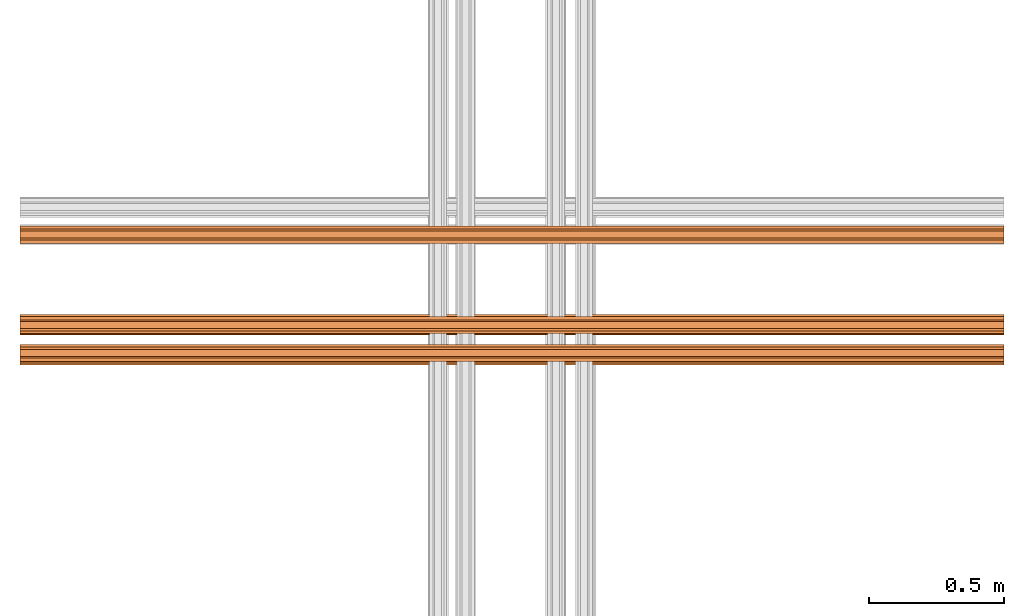
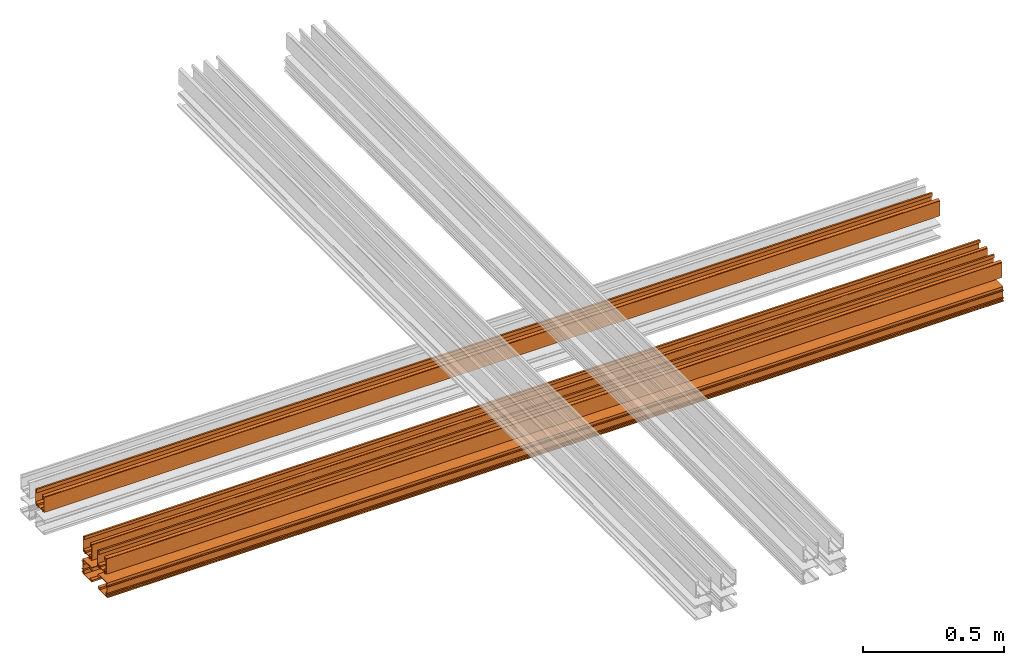
# One storey, part 1 of 4: 5 proxies.
"""IFC2X3 building model written with IfcOpenShell, lengths in feet."""

from ifc_helpers import new_model, entity, si_unit, converted_unit, derived_unit, direction, frame, origin, place, context, subcontext, project, spatial, polyline, outline, extrude, source, transform, mapped, material, type_object, type_shapes, element, save


model = new_model("IFC2X3")

# Units and contexts
model_context = context("Model", 3, precision=0.0001, world=origin(), true_north=direction((6.12303176911189e-17, 1.0)))
body_context = subcontext(model_context, "Body", "Model", "MODEL_VIEW")
ifc_project = project(units=[converted_unit("LENGTHUNIT", "FOOT", entity("IfcRatioMeasure", 0.3048), si_unit("LENGTHUNIT", "METRE"), dimensions=[1, 0, 0, 0, 0, 0, 0]), converted_unit("AREAUNIT", "SQUARE FOOT", entity("IfcRatioMeasure", 0.09290304), si_unit("AREAUNIT", "SQUARE_METRE"), dimensions=[2, 0, 0, 0, 0, 0, 0]), converted_unit("VOLUMEUNIT", "CUBIC FOOT", entity("IfcRatioMeasure", 0.028316846592), si_unit("VOLUMEUNIT", "CUBIC_METRE"), dimensions=[3, 0, 0, 0, 0, 0, 0]), converted_unit("PLANEANGLEUNIT", "DEGREE", entity("IfcRatioMeasure", 0.0174532925199433), si_unit("PLANEANGLEUNIT", "RADIAN"), dimensions=[0, 0, 0, 0, 0, 0, 0]), si_unit("MASSUNIT", "GRAM", prefix="KILO"), derived_unit("MASSDENSITYUNIT", [(si_unit("MASSUNIT", "GRAM", prefix="KILO"), 1), (si_unit("LENGTHUNIT", "METRE"), -3)]), si_unit("TIMEUNIT", "SECOND"), si_unit("FREQUENCYUNIT", "HERTZ"), si_unit("THERMODYNAMICTEMPERATUREUNIT", "DEGREE_CELSIUS"), derived_unit("THERMALTRANSMITTANCEUNIT", [(si_unit("MASSUNIT", "GRAM", prefix="KILO"), 1), (si_unit("THERMODYNAMICTEMPERATUREUNIT", "KELVIN"), -1), (si_unit("TIMEUNIT", "SECOND"), -3)]), derived_unit("VOLUMETRICFLOWRATEUNIT", [(si_unit("LENGTHUNIT", "METRE"), 3), (si_unit("TIMEUNIT", "SECOND"), -1)]), si_unit("ELECTRICCURRENTUNIT", "AMPERE"), si_unit("ELECTRICVOLTAGEUNIT", "VOLT"), si_unit("POWERUNIT", "WATT"), si_unit("FORCEUNIT", "NEWTON"), si_unit("ILLUMINANCEUNIT", "LUX"), si_unit("LUMINOUSFLUXUNIT", "LUMEN"), si_unit("LUMINOUSINTENSITYUNIT", "CANDELA"), derived_unit("USERDEFINED", [(si_unit("MASSUNIT", "GRAM", prefix="KILO"), -1), (si_unit("LENGTHUNIT", "METRE"), -2), (si_unit("TIMEUNIT", "SECOND"), 3), (si_unit("LUMINOUSFLUXUNIT", "LUMEN"), 1)]), derived_unit("LINEARVELOCITYUNIT", [(si_unit("LENGTHUNIT", "METRE"), 1), (si_unit("TIMEUNIT", "SECOND"), -1)]), si_unit("PRESSUREUNIT", "PASCAL"), derived_unit("USERDEFINED", [(si_unit("LENGTHUNIT", "METRE"), -2), (si_unit("MASSUNIT", "GRAM", prefix="KILO"), 1), (si_unit("TIMEUNIT", "SECOND"), -2)])], contexts=[model_context])

# Site, building, storey
site_placement = place(None, origin())
site = spatial("IfcSite", under=ifc_project, at=site_placement, CompositionType="ELEMENT")
building_placement = place(site_placement, origin())
building = spatial("IfcBuilding", under=site, at=building_placement, CompositionType="ELEMENT")
storey_placement = place(building_placement, origin())
storey = spatial("IfcBuildingStorey", under=building, at=storey_placement, Name="Level 1", CompositionType="ELEMENT", Elevation=0.0)

# Proxies
ifc_material = material(Name="THERMAL BROKEN ALUMINUM STOREFRONT FOR POLYCARBONATE")
building_element_proxy_type_1 = type_object("IfcBuildingElementProxyType", Name="Generic Models 2", PredefinedType="NOTDEFINED", material=ifc_material)
shared_shape_1 = source(origin(), body_context, "Body", "SweptSolid", [
    extrude(outline(polyline([(-0.0354587820648085, -0.057987428976448), (-0.0371114306935168, -0.0606344277326356), (-0.0357721806658748, -0.0632292686235394), (-0.0318167433379175, -0.0629517678914727), (-0.0277772795930213, -0.0651918706200439), (-0.0314564692543419, -0.0718263669125334), (-0.0224403589082045, -0.0768262913240349), (0.080199598822188, 0.108259143706009), (0.064548992183561, 0.116938257778831), (0.0595490677720596, 0.107922147432694), (0.0641808354764016, 0.104241425091678), (0.0513416446814541, 0.093122117241815), (0.0445492945375549, 0.0808738163942816), (0.0511837908300444, 0.0771946267329609), (-0.0196641946988638, -0.0505619557187231), (-0.0545378290564901, -0.0312226254478626), (-0.0567210844599416, -0.0351595792918124), (-0.0305624709345729, -0.0549725228627147), (-0.0322344006357104, -0.057987428976448), (-0.0354587820648085, -0.057987428976448)])), frame((0.0, -0.190699332335291, 0.0977165289076384), z_axis=(-1.0, 0.0, 0.0), x_axis=(0.0, -0.874528680516531, 0.484973800275866)), (0.0, 0.0, -1.0), 12.0),
    extrude(outline(polyline([(-0.0178285177675853, -0.0155260272187074), (-0.0144209943882479, -0.0155260272187074), (-0.0144209943882479, -0.00196676824874472), (-0.00206457119881483, -0.00196676824874479), (-0.00122137518562371, -0.00702594432743677), (0.0126070394294665, -0.00196676824874489), (0.027466410094602, -0.00196676824874498), (0.027466410094602, 0.00198764102988935), (0.0102463757664149, 0.0219787153649708), (-0.027829782456566, 0.021978715364971), (-0.0178285177675853, -0.0155260272187074)])), frame((0.0, -0.187517152962419, 0.217514651613355), z_axis=(1.0, 0.0, 0.0), x_axis=(0.0, 0.0, -1.0)), (0.0, 0.0, 1.0), 12.0),
    extrude(outline(polyline([(-0.10703462932325, -0.0730229494703186), (-0.10703462932325, -0.0580447359626438), (-0.113745897781071, -0.0580447359626438), (-0.118025006955696, -0.0623242255363626), (-0.112092207910207, -0.0623242255363626), (-0.112092207910207, -0.0671872818698963), (-0.11773967307098, -0.0704478474007052), (-0.125224643652343, -0.0704478474007052), (-0.131454279657517, -0.0675429204239743), (-0.131454279657517, -0.0623242255363626), (-0.124783598829804, -0.0623242255363626), (-0.125514243391176, -0.0580447359626438), (-0.142048634925557, -0.0580447359626438), (-0.140085232742292, -0.0813874063643331), (0.0647285203812249, -0.0813874063643331), (0.0647285203812249, -0.0697160711634884), (0.0853478792356714, -0.0697160711634884), (0.0853478792356714, -0.0631023145498281), (0.0647285203809975, -0.0631023145498281), (0.0647285203809975, -0.0273102199340561), (0.0853478792356715, -0.0273102199340561), (0.0853478792356715, -0.0206964633203958), (0.0647285203809975, -0.0206964633203958), (0.0647285203809975, 0.0812331974328894), (0.0853478792356714, 0.0812331974328894), (0.0853478792356714, 0.0878469540465497), (0.0647285203812249, 0.0878469540465497), (0.0647285203812249, 0.116052680781773), (0.0602545085540829, 0.116052680781773), (0.0585038082739668, 0.113329369234955), (0.0606435530609293, 0.110217013181205), (0.0606435530609293, 0.0878469540467771), (0.0563640634872104, 0.0835674644730583), (0.0563640634872105, 0.0713125625121714), (0.0388570606861708, 0.0713125625121714), (0.0388570606861709, 0.11546911402173), (0.033799482099214, 0.11546911402173), (0.033799482099214, 0.0646988058985111), (0.0563640634872104, 0.0646988058985111), (0.0563640634872105, -0.0203074188135494), (0.033799482099214, -0.0203074188135494), (0.033799482099214, -0.0730229494703186), (-0.10703462932325, -0.0730229494703186)]), holes=[polyline([(0.0577257192607181, -0.0710777269369961), (0.0388570606861709, -0.0710777269369961), (0.0388570606861709, -0.0273102199340561), (0.0577257192607181, -0.0273102199340561), (0.0577257192607181, -0.0710777269369961)])]), frame((0.0, -0.0813874063643477, 0.0853478792356716), z_axis=(-1.0, 0.0, 0.0), x_axis=(0.0, 0.0, -1.0)), (0.0, 0.0, -1.0), 12.0),
    extrude(outline(polyline([(-0.0292228042856085, -0.0158518272304065), (0.0188500922736237, -0.0158518272304065), (0.0188500922736237, -0.00589636662728312), (0.0115395937546053, -0.00589636662728311), (0.00550806035789697, 0.000135166769425167), (0.0129043470694795, 0.000135166769425165), (0.0129043470694795, 0.00370861456478618), (0.00801477925506001, 0.00653160785866192), (0.00118965299247954, 0.00653160785866192), (-0.00472072620232233, 0.00377555277752608), (-0.00472072620232233, 0.000414827901224136), (0.00196648946985067, 0.000414827901224136), (0.00088896845272922, -0.00589636662728308), (-0.0169597840697408, -0.00589636662728307), (-0.0150489881052633, 0.0168208742845053), (-0.0219433941035701, 0.0168208742845053), (-0.0292228042856085, -0.0158518272304065)])), frame((0.0, -0.0184530145665469, 0.211232600832546), z_axis=(1.0, 0.0, 0.0), x_axis=(0.0, 0.0, -1.0)), (0.0, 0.0, 1.0), 12.0),
])
type_shapes(building_element_proxy_type_1, [shared_shape_1])
proxy_1_placement = place(storey_placement, frame((0.0, 0.0, 0.30116151530084)))
element("IfcBuildingElementProxy", 1, at=proxy_1_placement, inside=storey, type_object=building_element_proxy_type_1, material=ifc_material, Name="Generic Models 2:Generic Models 2", ObjectType="Generic Models 2:Generic Models 2", context=body_context, shape_type="MappedRepresentation", body=[
    mapped(shared_shape_1, transform((0.0, 0.0, 0.0), scale=1.0)),
])
building_element_proxy_type_2 = type_object("IfcBuildingElementProxyType", Name="Generic Models 2", PredefinedType="NOTDEFINED", material=ifc_material)
shared_shape_2 = source(origin(), body_context, "Body", "SweptSolid", [
    extrude(outline(polyline([(0.0679666623619384, 0.000632417738882162), (0.0710872151823903, 0.000632417738882162), (0.0725790120391962, 0.00314266314992655), (0.0702488184526767, 0.00635088523716425), (0.0700096732994308, 0.0109637083615168), (0.0775858665392128, 0.0113564851588286), (0.07705209294287, 0.0216523375102515), (-0.134304272308872, 0.0106948719853338), (-0.133377721915217, -0.00717717360587128), (-0.123081869563794, -0.00664340000952848), (-0.122412698736183, -0.000765203056200318), (-0.106181130798194, -0.00576720561552888), (-0.0921943125095252, -0.00504207922050014), (-0.0925870893068369, 0.00253411401928196), (0.0533031958989614, 0.0100975851674487), (0.0553677918848112, -0.0297259946823093), (0.0598635549062831, -0.0294929183410441), (0.0628161856570255, 0.00318899968962131), (0.0662590259738257, 0.00336748877384745), (0.0679666623619384, 0.000632417738882162)])), frame((0.0, 0.320001633810788, 0.0977165289076384), z_axis=(1.0, 0.0, 0.0), x_axis=(0.0, -0.0517740246052127, -0.998658825813991)), (0.0, 0.0, 1.0), 12.0),
    extrude(outline(polyline([(-0.0104080468283571, -0.0212270141141865), (0.0284072982254618, -0.0212270141141865), (0.0185964943745739, 0.0155635003266429), (-0.00515653981588804, 0.0270511459549446), (-0.00897742822638789, 0.0260322423788113), (-0.00514872339515063, 0.0116745992616715), (-0.0064740101252062, -0.00299045881680825), (-0.00136839731267844, -0.0025016235475988), (0.00181539143775603, -0.0144408313617281), (-0.0112860383341235, -0.0179345459675626), (-0.0104080468283571, -0.0212270141141865)])), frame((0.0, 0.316819454437916, 0.217514651613355), z_axis=(1.0, 0.0, 0.0), x_axis=(0.0, -0.966234939601246, 0.257662650560335)), (0.0, 0.0, 1.0), 12.0),
    extrude(outline(polyline([(-0.0730229494703184, 0.10703462932325), (-0.0580447359626436, 0.10703462932325), (-0.0580447359626435, 0.113745897781071), (-0.0623242255363624, 0.118025006955696), (-0.0623242255363624, 0.112092207910207), (-0.067187281869896, 0.112092207910207), (-0.0704478474007049, 0.11773967307098), (-0.0704478474007049, 0.125224643652343), (-0.067542920423974, 0.131454279657517), (-0.0623242255363623, 0.131454279657517), (-0.0623242255363623, 0.124783598829804), (-0.0580447359626436, 0.125514243391176), (-0.0580447359626435, 0.142048634925557), (-0.0813874063643328, 0.140085232742292), (-0.0813874063643332, -0.0647285203812247), (-0.0697160711634885, -0.0647285203812247), (-0.0697160711634886, -0.0853478792356713), (-0.0631023145498282, -0.0853478792356713), (-0.0631023145498282, -0.0647285203809974), (-0.0273102199340562, -0.0647285203809974), (-0.0273102199340562, -0.0853478792356714), (-0.0206964633203959, -0.0853478792356714), (-0.0206964633203959, -0.0647285203809975), (0.0812331974328893, -0.0647285203809976), (0.0812331974328893, -0.0853478792356716), (0.0878469540465496, -0.0853478792356716), (0.0878469540465496, -0.064728520381225), (0.116052680781773, -0.0647285203812251), (0.116052680781773, -0.060254508554083), (0.113329369234955, -0.058503808273967), (0.110217013181205, -0.0606435530609294), (0.0878469540467771, -0.0606435530609294), (0.0835674644730583, -0.0563640634872106), (0.0713125625121714, -0.0563640634872106), (0.0713125625121713, -0.038857060686171), (0.11546911402173, -0.0388570606861711), (0.11546911402173, -0.0337994820992142), (0.064698805898511, -0.0337994820992141), (0.064698805898511, -0.0563640634872105), (-0.0203074188135494, -0.0563640634872104), (-0.0203074188135494, -0.033799482099214), (-0.0730229494703186, -0.0337994820992139), (-0.0730229494703184, 0.10703462932325)]), holes=[polyline([(-0.0710777269369962, -0.057725719260718), (-0.0710777269369962, -0.0388570606861707), (-0.0273102199340562, -0.0388570606861708), (-0.0273102199340562, -0.0577257192607181), (-0.0710777269369962, -0.057725719260718)])]), frame((0.0, 0.210689707839845, 0.0853478792356716), z_axis=(1.0, 0.0, 0.0), x_axis=(0.0, 1.0, 0.0)), (0.0, 0.0, 1.0), 12.0),
    extrude(outline(polyline([(-0.0218274236802372, -0.0250762096884888), (0.0116463755794956, -0.0250762096884888), (0.0131456738465899, -0.0183468011873071), (-0.00944342914962784, -0.0152716423802919), (-0.00556193395869954, 0.00214995231397123), (0.000832544625431264, 0.00182921635388849), (-0.000621696809064671, -0.00469796031725742), (0.00265859892029523, -0.00542880340721438), (0.00663400184610042, -0.000259219921661488), (0.00811823413249319, 0.00640256685218492), (0.00642611525779217, 0.0117890219260675), (0.00293818751194471, 0.0125661249989722), (0.00132974729935321, 0.0053468468354401), (-0.00324578604653776, 0.01254568596629), (-0.00165600184121947, 0.0196812290274094), (-0.0113732075341089, 0.0218462023164868), (-0.0218274236802372, -0.0250762096884888)])), frame((0.0, 0.147755316042044, 0.211232600832546), z_axis=(1.0, 0.0, 0.0), x_axis=(0.0, -0.976067916921979, -0.217465908950321)), (0.0, 0.0, 1.0), 12.0),
])
type_shapes(building_element_proxy_type_2, [shared_shape_2])
proxy_2_placement = place(storey_placement, frame((0.0, 0.0, 0.30116151530084)))
element("IfcBuildingElementProxy", 2, at=proxy_2_placement, inside=storey, type_object=building_element_proxy_type_2, material=ifc_material, Name="Generic Models 1:Generic Models 2", ObjectType="Generic Models 1:Generic Models 2", context=body_context, shape_type="MappedRepresentation", body=[
    mapped(shared_shape_2, transform((0.0, 0.0, 0.0), scale=1.0)),
])
building_element_proxy_type_3 = type_object("IfcBuildingElementProxyType", Name="Generic Models 2", PredefinedType="NOTDEFINED", material=ifc_material)
shared_shape_3 = source(origin(), body_context, "Body", "SweptSolid", [
    extrude(outline(polyline([(-0.10703462932325, -0.0730229494703186), (-0.10703462932325, -0.0580447359626438), (-0.113745897781071, -0.0580447359626439), (-0.118025006955696, -0.0623242255363627), (-0.112092207910207, -0.0623242255363626), (-0.112092207910207, -0.0671872818698964), (-0.11773967307098, -0.0704478474007053), (-0.125224643652343, -0.0704478474007053), (-0.131454279657517, -0.0675429204239743), (-0.131454279657516, -0.0623242255363626), (-0.124783598829804, -0.0623242255363625), (-0.125514243391176, -0.0580447359626438), (-0.142048634925557, -0.0580447359626438), (-0.140085232742292, -0.0813874063643331), (0.0647285203812249, -0.0813874063643332), (0.0647285203812249, -0.0697160711634884), (0.0853478792356715, -0.0697160711634884), (0.0853478792356715, -0.0631023145498281), (0.0647285203809975, -0.0631023145498281), (0.0647285203809975, -0.0273102199340562), (0.0853478792356714, -0.0273102199340561), (0.0853478792356714, -0.0206964633203958), (0.0647285203809975, -0.0206964633203958), (0.0647285203809975, 0.0812331974328894), (0.0853478792356714, 0.0812331974328894), (0.0853478792356715, 0.0878469540465497), (0.0647285203812249, 0.0878469540465497), (0.0647285203812249, 0.116052680781773), (0.0602545085540829, 0.116052680781773), (0.0585038082739668, 0.113329369234955), (0.0606435530609293, 0.110217013181205), (0.0606435530609293, 0.0878469540467771), (0.0563640634872105, 0.0835674644730583), (0.0563640634872105, 0.0713125625121714), (0.0388570606861709, 0.0713125625121714), (0.0388570606861709, 0.11546911402173), (0.033799482099214, 0.11546911402173), (0.033799482099214, 0.0646988058985111), (0.0563640634872105, 0.0646988058985111), (0.0563640634872105, -0.0203074188135494), (0.033799482099214, -0.0203074188135494), (0.033799482099214, -0.0730229494703186), (-0.10703462932325, -0.0730229494703186)]), holes=[polyline([(0.0577257192607181, -0.0710777269369961), (0.0388570606861709, -0.0710777269369962), (0.0388570606861709, -0.0273102199340561), (0.0577257192607181, -0.0273102199340561), (0.0577257192607181, -0.0710777269369961)])]), frame((0.0, -0.117978010729643, -0.219774108936509), z_axis=(-1.0, 0.0, 0.0), x_axis=(0.0, -1.0, 0.0)), (0.0, 0.0, -1.0), 12.0),
    extrude(outline(polyline([(-0.035458782064809, -0.0579874289764477), (-0.0371114306935174, -0.0606344277326353), (-0.0357721806658754, -0.0632292686235391), (-0.031816743337918, -0.0629517678914724), (-0.0277772795930219, -0.0651918706200437), (-0.0314564692543425, -0.0718263669125332), (-0.0224403589082052, -0.0768262913240348), (0.0801995988221891, 0.108259143706008), (0.0645489921835621, 0.116938257778831), (0.0595490677720606, 0.107922147432693), (0.0641808354764026, 0.104241425091677), (0.0513416446814549, 0.0931221172418145), (0.0445492945375557, 0.0808738163942812), (0.0511837908300452, 0.0771946267329605), (-0.0196641946988643, -0.0505619557187229), (-0.0545378290564904, -0.0312226254478621), (-0.056721084459942, -0.0351595792918119), (-0.0305624709345734, -0.0549725228627144), (-0.0322344006357109, -0.0579874289764477), (-0.035458782064809, -0.0579874289764477)])), frame((0.0, -0.105609361057676, -0.110462182965566), z_axis=(-1.0, 0.0, 0.0), x_axis=(0.0, 0.484973800275872, 0.874528680516527)), (0.0, 0.0, -1.0), 12.0),
    extrude(outline(polyline([(-0.0178285177675856, -0.015526027218707), (-0.0144209943882483, -0.015526027218707), (-0.0144209943882479, -0.00196676824874445), (-0.00206457119881486, -0.00196676824874474), (-0.00122137518562389, -0.00702594432743677), (0.0126070394294665, -0.00196676824874522), (0.027466410094602, -0.00196676824874559), (0.0274664100946021, 0.00198764102988874), (0.0102463757664154, 0.0219787153649705), (-0.0278297824565654, 0.0219787153649716), (-0.0178285177675856, -0.015526027218707)])), frame((0.0, 0.0141887616480401, -0.113644362338437), z_axis=(1.0, 0.0, 0.0), x_axis=(0.0, -1.0, 0.0)), (0.0, 0.0, 1.0), 12.0),
    extrude(outline(polyline([(-0.0292228042856086, -0.0158518272304064), (0.0188500922736237, -0.0158518272304064), (0.0188500922736237, -0.00589636662728305), (0.0115395937546053, -0.00589636662728303), (0.00550806035789696, 0.000135166769425191), (0.0129043470694794, 0.000135166769425221), (0.0129043470694794, 0.00370861456478623), (0.00801477925505999, 0.00653160785866194), (0.00118965299247949, 0.00653160785866197), (-0.00472072620232236, 0.00377555277752608), (-0.00472072620232237, 0.000414827901224118), (0.00196648946985058, 0.000414827901224151), (0.000888968452729204, -0.00589636662728305), (-0.0169597840697408, -0.0058963666272831), (-0.0150489881052633, 0.0168208742845054), (-0.0219433941035702, 0.0168208742845054), (-0.0292228042856086, -0.0158518272304064)])), frame((0.0, 0.00790671086723129, -0.28270850073431), z_axis=(1.0, 0.0, 0.0), x_axis=(0.0, -1.0, 0.0)), (0.0, 0.0, 1.0), 12.0),
])
type_shapes(building_element_proxy_type_3, [shared_shape_3])
proxy_3_placement = place(storey_placement, frame((0.0, -0.0468749999999995, 0.30116151530084)))
element("IfcBuildingElementProxy", 3, at=proxy_3_placement, inside=storey, type_object=building_element_proxy_type_3, material=ifc_material, Name="Generic Models 5:Generic Models 2", ObjectType="Generic Models 5:Generic Models 2", context=body_context, shape_type="MappedRepresentation", body=[
    mapped(shared_shape_3, transform((0.0, 0.0, 0.0), scale=1.0)),
])
building_element_proxy_type_4 = type_object("IfcBuildingElementProxyType", Name="Generic Models 2", PredefinedType="NOTDEFINED", material=ifc_material)
shared_shape_4 = source(origin(), body_context, "Body", "SweptSolid", [
    extrude(outline(polyline([(-0.0730229494703184, 0.10703462932325), (-0.0580447359626436, 0.10703462932325), (-0.0580447359626437, 0.113745897781071), (-0.0623242255363624, 0.118025006955696), (-0.0623242255363625, 0.112092207910207), (-0.0671872818698961, 0.112092207910207), (-0.070447847400705, 0.11773967307098), (-0.070447847400705, 0.125224643652343), (-0.067542920423974, 0.131454279657517), (-0.0623242255363624, 0.131454279657517), (-0.0623242255363624, 0.124783598829804), (-0.0580447359626436, 0.125514243391176), (-0.0580447359626436, 0.142048634925557), (-0.0813874063643329, 0.140085232742292), (-0.0813874063643329, -0.0647285203812248), (-0.0697160711634882, -0.0647285203812248), (-0.0697160711634882, -0.0853478792356714), (-0.0631023145498278, -0.0853478792356714), (-0.0631023145498279, -0.0647285203809975), (-0.0273102199340559, -0.0647285203809975), (-0.0273102199340559, -0.0853478792356714), (-0.0206964633203955, -0.0853478792356714), (-0.0206964633203956, -0.0647285203809975), (0.0812331974328896, -0.0647285203809974), (0.0812331974328896, -0.0853478792356714), (0.08784695404655, -0.0853478792356713), (0.0878469540465499, -0.0647285203812248), (0.116052680781773, -0.0647285203812248), (0.116052680781773, -0.0602545085540828), (0.113329369234955, -0.0585038082739667), (0.110217013181205, -0.0606435530609292), (0.0878469540467774, -0.0606435530609292), (0.0835674644730585, -0.0563640634872104), (0.0713125625121717, -0.0563640634872104), (0.0713125625121716, -0.0388570606861709), (0.115469114021731, -0.0388570606861708), (0.115469114021731, -0.0337994820992139), (0.0646988058985113, -0.033799482099214), (0.0646988058985113, -0.0563640634872104), (-0.0203074188135491, -0.0563640634872104), (-0.0203074188135492, -0.033799482099214), (-0.0730229494703184, -0.033799482099214), (-0.0730229494703184, 0.10703462932325)]), holes=[polyline([(-0.0710777269369959, -0.0577257192607181), (-0.0710777269369959, -0.0388570606861708), (-0.0273102199340559, -0.0388570606861709), (-0.0273102199340559, -0.0577257192607181), (-0.0710777269369959, -0.0577257192607181)])]), frame((0.0, 0.276330802761896, -0.219774108936507), z_axis=(1.0, 0.0, 0.0), x_axis=(0.0, 0.0, 1.0)), (0.0, 0.0, 1.0), 12.0),
    extrude(outline(polyline([(0.0679666623619385, 0.000632417738883059), (0.0710872151823904, 0.000632417738883059), (0.0725790120391962, 0.00314266314992747), (0.0702488184526767, 0.00635088523716513), (0.0700096732994307, 0.0109637083615177), (0.0775858665392127, 0.0113564851588296), (0.0770520929428698, 0.0216523375102526), (-0.134304272308872, 0.0106948719853316), (-0.133377721915217, -0.00717717360587345), (-0.123081869563794, -0.00664340000953058), (-0.122412698736183, -0.000765203056202354), (-0.106181130798194, -0.0057672056155308), (-0.092194312509525, -0.00504207922050176), (-0.0925870893068369, 0.00253411401928028), (0.0533031958989614, 0.0100975851674494), (0.0553677918848117, -0.0297259946823085), (0.0598635549062837, -0.0294929183410433), (0.0628161856570255, 0.00318899968962212), (0.0662590259738257, 0.00336748877384826), (0.0679666623619385, 0.000632417738883059)])), frame((0.0, 0.263962153089929, -0.110462182965564), z_axis=(1.0, 0.0, 0.0), x_axis=(0.0, 0.99865882581399, -0.05177402460523)), (0.0, 0.0, 1.0), 12.0),
    extrude(outline(polyline([(-0.0104080468283572, -0.0212270141141865), (0.0284072982254618, -0.0212270141141865), (0.018596494374574, 0.0155635003266429), (-0.00515653981588794, 0.0270511459549447), (-0.00897742822638779, 0.0260322423788114), (-0.00514872339515059, 0.0116745992616716), (-0.00647401012520621, -0.00299045881680825), (-0.00136839731267844, -0.00250162354759877), (0.00181539143775596, -0.0144408313617281), (-0.0112860383341236, -0.0179345459675626), (-0.0104080468283572, -0.0212270141141865)])), frame((0.0, 0.144164030384213, -0.113644362338435), z_axis=(1.0, 0.0, 0.0), x_axis=(0.0, -0.257662650560335, -0.966234939601246)), (0.0, 0.0, 1.0), 12.0),
    extrude(outline(polyline([(-0.0218274236802371, -0.0250762096884888), (0.0116463755794956, -0.0250762096884888), (0.0131456738465899, -0.018346801187307), (-0.00944342914962784, -0.015271642380292), (-0.00556193395869958, 0.00214995231397121), (0.000832544625431163, 0.00182921635388846), (-0.000621696809064745, -0.00469796031725746), (0.00265859892029524, -0.00542880340721442), (0.00663400184610037, -0.000259219921661535), (0.00811823413249318, 0.0064025668521849), (0.00642611525779216, 0.0117890219260674), (0.00293818751194459, 0.0125661249989721), (0.00132974729935322, 0.00534684683544013), (-0.0032457860465378, 0.0125456859662899), (-0.00165600184121952, 0.0196812290274094), (-0.011373207534109, 0.0218462023164867), (-0.0218274236802371, -0.0250762096884888)])), frame((0.0, 0.150446081165022, -0.282708500734308), z_axis=(1.0, 0.0, 0.0), x_axis=(0.0, 0.217465908950317, -0.97606791692198)), (0.0, 0.0, 1.0), 12.0),
])
type_shapes(building_element_proxy_type_4, [shared_shape_4])
proxy_4_placement = place(storey_placement, frame((0.0, 0.0, 0.30116151530084)))
element("IfcBuildingElementProxy", 4, at=proxy_4_placement, inside=storey, type_object=building_element_proxy_type_4, material=ifc_material, Name="Generic Models 6:Generic Models 2", ObjectType="Generic Models 6:Generic Models 2", context=body_context, shape_type="MappedRepresentation", body=[
    mapped(shared_shape_4, transform((0.0, 0.0, 0.0), scale=1.0)),
])
building_element_proxy_type_5 = type_object("IfcBuildingElementProxyType", Name="Generic Models 2", PredefinedType="NOTDEFINED", material=ifc_material)
shared_shape_5 = source(origin(), body_context, "Body", "SweptSolid", [
    extrude(outline(polyline([(-0.0354587820648092, -0.0579874289764476), (-0.0371114306935175, -0.0606344277326351), (-0.0357721806658755, -0.0632292686235389), (-0.0318167433379183, -0.0629517678914723), (-0.0277772795930221, -0.0651918706200435), (-0.0314564692543428, -0.071826366912533), (-0.0224403589082054, -0.0768262913240346), (0.0801995988221894, 0.108259143706008), (0.0645489921835626, 0.11693825777883), (0.059549067772061, 0.107922147432693), (0.0641808354764031, 0.104241425091677), (0.0513416446814554, 0.0931221172418144), (0.0445492945375561, 0.080873816394281), (0.0511837908300456, 0.0771946267329603), (-0.0196641946988643, -0.0505619557187229), (-0.0545378290564905, -0.0312226254478618), (-0.0567210844599421, -0.0351595792918117), (-0.0305624709345735, -0.0549725228627142), (-0.0322344006357111, -0.0579874289764476), (-0.0354587820648092, -0.0579874289764476)])), frame((0.0, 1.24954979914876, 0.398878044208478), z_axis=(-1.0, 0.0, 0.0), x_axis=(0.0, -0.874528680516525, 0.484973800275877)), (0.0, 0.0, -1.0), 12.0),
    extrude(outline(polyline([(-0.0178285177675852, -0.0155260272187077), (-0.014420994388248, -0.0155260272187077), (-0.014420994388248, -0.00196676824874498), (-0.00206457119881487, -0.00196676824874498), (-0.00122137518562382, -0.00702594432743697), (0.0126070394294664, -0.00196676824874498), (0.0274664100946019, -0.00196676824874498), (0.0274664100946019, 0.00198764102988935), (0.0102463757664146, 0.0219787153649706), (-0.0278297824565662, 0.0219787153649706), (-0.0178285177675852, -0.0155260272187077)])), frame((0.0, 1.25273197852163, 0.518676166914195), z_axis=(1.0, 0.0, 0.0), x_axis=(0.0, 0.0, -1.0)), (0.0, 0.0, 1.0), 12.0),
    extrude(outline(polyline([(-0.10703462932325, -0.0730229494703184), (-0.10703462932325, -0.0580447359626436), (-0.113745897781071, -0.0580447359626436), (-0.118025006955696, -0.0623242255363625), (-0.112092207910207, -0.0623242255363624), (-0.112092207910207, -0.0671872818698961), (-0.11773967307098, -0.070447847400705), (-0.125224643652343, -0.070447847400705), (-0.131454279657516, -0.0675429204239741), (-0.131454279657516, -0.0623242255363625), (-0.124783598829804, -0.0623242255363625), (-0.125514243391176, -0.0580447359626437), (-0.142048634925556, -0.0580447359626437), (-0.140085232742292, -0.0813874063643329), (0.064728520381225, -0.0813874063643327), (0.064728520381225, -0.0697160711634881), (0.0853478792356716, -0.0697160711634881), (0.0853478792356715, -0.0631023145498277), (0.0647285203809976, -0.0631023145498277), (0.0647285203809976, -0.0273102199340558), (0.0853478792356715, -0.0273102199340558), (0.0853478792356715, -0.0206964633203954), (0.0647285203809976, -0.0206964633203954), (0.0647285203809974, 0.0812331974328897), (0.0853478792356714, 0.0812331974328897), (0.0853478792356713, 0.0878469540465501), (0.0647285203812248, 0.0878469540465501), (0.0647285203812248, 0.116052680781773), (0.0602545085540827, 0.116052680781773), (0.0585038082739666, 0.113329369234955), (0.0606435530609292, 0.110217013181205), (0.0606435530609292, 0.0878469540467774), (0.0563640634872104, 0.0835674644730586), (0.0563640634872104, 0.0713125625121717), (0.0388570606861708, 0.0713125625121717), (0.0388570606861708, 0.115469114021731), (0.0337994820992139, 0.115469114021731), (0.0337994820992139, 0.0646988058985113), (0.0563640634872104, 0.0646988058985114), (0.0563640634872105, -0.0203074188135491), (0.0337994820992141, -0.0203074188135491), (0.0337994820992141, -0.0730229494703184), (-0.10703462932325, -0.0730229494703184)]), holes=[polyline([(0.0577257192607182, -0.0710777269369958), (0.038857060686171, -0.0710777269369959), (0.0388570606861709, -0.0273102199340559), (0.0577257192607182, -0.0273102199340558), (0.0577257192607182, -0.0710777269369958)])]), frame((0.0, 1.3588617251197, 0.386509394536512), z_axis=(-1.0, 0.0, 0.0), x_axis=(0.0, 0.0, -1.0)), (0.0, 0.0, -1.0), 12.0),
    extrude(outline(polyline([(-0.0292228042856085, -0.0158518272304069), (0.0188500922736238, -0.0158518272304069), (0.0188500922736238, -0.00589636662728354), (0.0115395937546053, -0.00589636662728354), (0.00550806035789708, 0.000135166769424711), (0.0129043470694795, 0.000135166769424711), (0.0129043470694794, 0.00370861456478577), (0.00801477925506, 0.00653160785866147), (0.00118965299247953, 0.00653160785866147), (-0.00472072620232233, 0.00377555277752561), (-0.00472072620232233, 0.000414827901223713), (0.00196648946985067, 0.000414827901223713), (0.000888968452729344, -0.00589636662728354), (-0.0169597840697407, -0.00589636662728354), (-0.0150489881052633, 0.0168208742845049), (-0.0219433941035703, 0.0168208742845049), (-0.0292228042856085, -0.0158518272304069)])), frame((0.0, 1.42179611691751, 0.512394116133386), z_axis=(1.0, 0.0, 0.0), x_axis=(0.0, 0.0, -1.0)), (0.0, 0.0, 1.0), 12.0),
])
type_shapes(building_element_proxy_type_5, [shared_shape_5])
proxy_5_placement = place(storey_placement, origin())
element("IfcBuildingElementProxy", 5, at=proxy_5_placement, inside=storey, type_object=building_element_proxy_type_5, material=ifc_material, Name="Generic Models 3:Generic Models 2", ObjectType="Generic Models 3:Generic Models 2", context=body_context, shape_type="MappedRepresentation", body=[
    mapped(shared_shape_5, transform((0.0, 0.0, 0.0), scale=1.0)),
])

save(model, "model.ifc")
